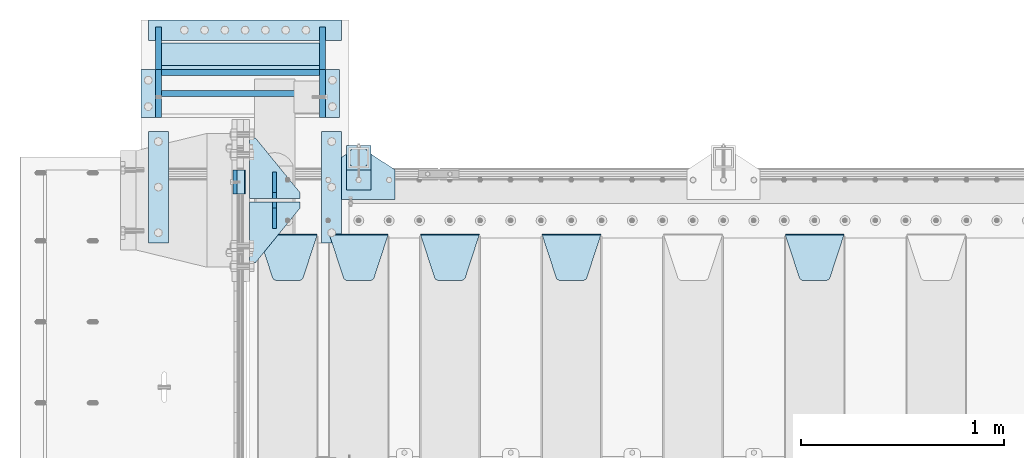
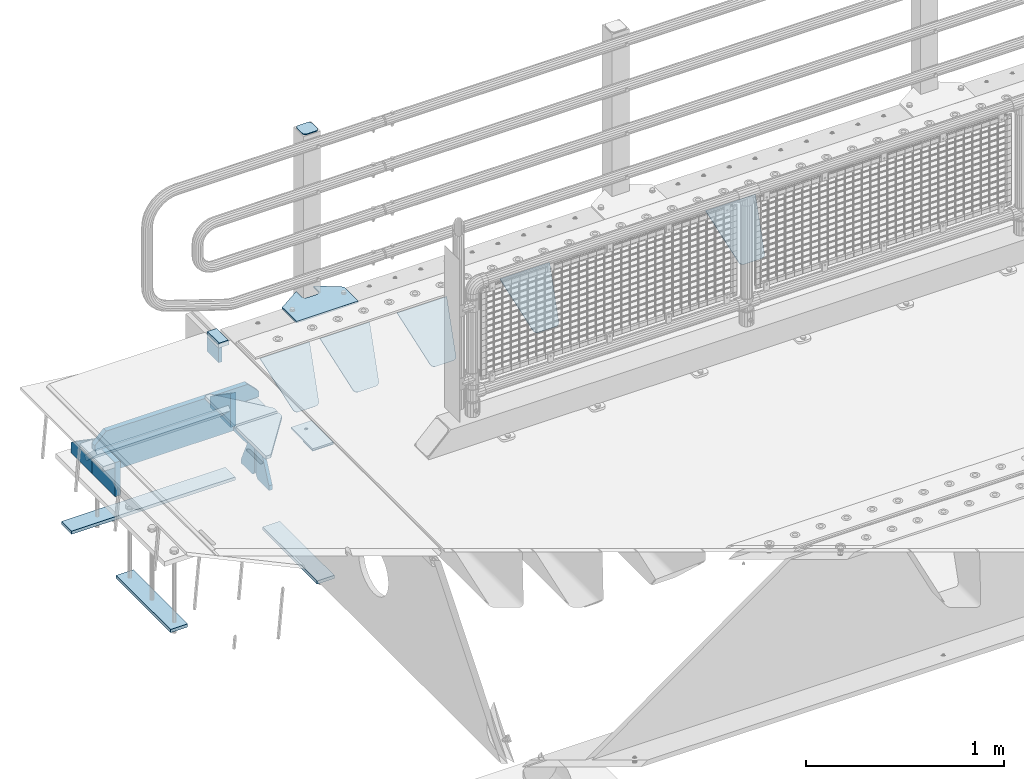
# One storey, part 222 of 257: 27 plates.
"""IFC2X3 building model written with IfcOpenShell, lengths in millimetres."""

from ifc_helpers import new_model, si_unit, frame, origin_with_axes, place, context, subcontext, project, spatial, faceted_brep, material, type_object, element, save


model = new_model("IFC2X3")

# Units and contexts
model_context = context("Model", 3, precision=1e-05, world=origin_with_axes())
body_context = subcontext(model_context, "Body", "Model", "MODEL_VIEW")
ifc_project = project(units=[si_unit("LENGTHUNIT", "METRE", prefix="MILLI"), si_unit("AREAUNIT", "SQUARE_METRE"), si_unit("VOLUMEUNIT", "CUBIC_METRE"), si_unit("MASSUNIT", "GRAM", prefix="KILO"), si_unit("TIMEUNIT", "SECOND"), si_unit("PLANEANGLEUNIT", "RADIAN"), si_unit("SOLIDANGLEUNIT", "STERADIAN"), si_unit("THERMODYNAMICTEMPERATUREUNIT", "DEGREE_CELSIUS"), si_unit("LUMINOUSINTENSITYUNIT", "LUMEN")], contexts=[model_context])

# Site, building, storey
site_placement = place(None, origin_with_axes())
site = spatial("IfcSite", under=ifc_project, at=site_placement, CompositionType="ELEMENT")
building_placement = place(site_placement, origin_with_axes())
building = spatial("IfcBuilding", under=site, at=building_placement, Name="Standard", CompositionType="ELEMENT")
storey_placement = place(building_placement, origin_with_axes())
storey = spatial("IfcBuildingStorey", under=building, at=storey_placement, Name="Undefined", CompositionType="ELEMENT", Elevation=0.0)

# Plates
ifc_material_1 = material()
plate_type_1 = type_object("IfcPlateType", PredefinedType="NOTDEFINED")
plate_1_placement = place(storey_placement, frame((42440.0, 12090.0, -16.0000571410064), z_axis=(-1.0, 0.0, 0.0), x_axis=(0.0, 0.0, 1.0)))
element("IfcPlate", 1, at=plate_1_placement, inside=storey, type_object=plate_type_1, material=ifc_material_1, context=body_context, shape_type="Brep", body=[
    faceted_brep([(0.0, -60.0, 0.0), (2.49929499318569e-09, -59.9999999999991, 60.0), (2.49929144047201e-09, 60.0000000000005, 60.0), (0.0, 60.0, -7.27595761418343e-12), (25.0146748218828, -59.9999999999991, 60.0), (25.0146748218828, 60.0000000000005, 60.0), (26.5597449794466, -59.9999999999991, 59.7552873949098), (26.5597449794466, 60.0000000000005, 59.7552873949098), (27.9535758796897, -59.9999999999991, 59.0451032832789), (27.9535758796897, 60.0000000000009, 59.0451032832789), (29.0597323263517, -59.9999999999991, 57.9389640667287), (29.0597323263517, 60.0000000000005, 57.9389640667287), (29.7699381491534, -59.9999999999991, 56.5451442289705), (29.7699381491534, 60.0000000000009, 56.5451442289705), (30.0146748212763, -59.9999999999991, 55.0000778834001), (30.0146748212762, 60.0000000000009, 55.0000778834001), (30.0154536553013, -59.9999999999991, 5.00007788340736), (30.0154536553013, 60.0000000000005, 5.00007788340736), (29.7707554908505, -59.9999999999991, 3.45497428546514), (29.7707554908505, 60.0000000000009, 3.45497428546514), (29.0605660948355, -59.9999999999995, 2.06111154406972), (29.0605660948355, 60.0000000000009, 2.06111154406972), (27.9544051209123, -59.9999999999995, 0.954933339693525), (27.9544051209123, 60.0000000000009, 0.954933339693525), (26.5605534420796, -59.9999999999991, 0.244722232011554), (26.5605534420796, 60.0000000000009, 0.244722232011554), (25.0154536559091, -59.9999999999991, 7.27595761418343e-12), (25.0154536559091, 60.0000000000009, 7.27595761418343e-12)], [[[0, 1, 2, 3]], [[1, 4, 5, 2]], [[4, 6, 7, 5]], [[6, 8, 9, 7]], [[8, 10, 11, 9]], [[10, 12, 13, 11]], [[12, 14, 15, 13]], [[14, 16, 17, 15]], [[16, 18, 19, 17]], [[18, 20, 21, 19]], [[20, 22, 23, 21]], [[22, 24, 25, 23]], [[24, 26, 27, 25]], [[26, 0, 3, 27]], [[5, 7, 9, 11, 13, 15, 17, 19, 21, 23, 25, 27, 3, 2]], [[26, 24, 22, 20, 18, 16, 14, 12, 10, 8, 6, 4, 1, 0]]]),
])
ifc_material_2 = material(Name="STEEL/S355N")
plate_type_2 = type_object("IfcPlateType", PredefinedType="NOTDEFINED")
plate_2_placement = place(storey_placement, frame((42390.0, 12150.0000855345, -105.984391681158), z_axis=(0.0, -1.0, 0.0), x_axis=(0.0, 0.0, 1.0)))
element("IfcPlate", 2, at=plate_2_placement, inside=storey, type_object=plate_type_2, material=ifc_material_2, context=body_context, shape_type="Brep", body=[
    faceted_brep([(0.0, -10.0, 0.0), (5.7072624315424e-07, -10.0, 120.0), (5.7072624315424e-07, 10.0, 120.0), (0.0, 10.0, 0.0), (89.9845046997072, -10.0, 119.999999999999), (89.9845046997072, 10.0, 119.999999999999), (89.9843902587891, -10.0, 6.45741238258779e-11), (89.9843902587891, 10.0, 6.45741238258779e-11)], [[[0, 1, 2, 3]], [[1, 4, 5, 2]], [[4, 6, 7, 5]], [[6, 0, 3, 7]], [[5, 7, 3, 2]], [[6, 4, 1, 0]]]),
])
plate_type_3 = type_object("IfcPlateType", PredefinedType="NOTDEFINED")
plate_3_placement = place(storey_placement, frame((45105.0, 11831.7677669559, -1.767766952965), z_axis=(0.0, -0.707106781186548, -0.707106781186547), x_axis=(1.0, 0.0, 0.0)))
element("IfcPlate", 3, at=plate_3_placement, inside=storey, type_object=plate_type_3, material=ifc_material_2, context=body_context, shape_type="Brep", body=[
    faceted_brep([(0.0, -2.5, 0.0), (69.345504679477, -2.50000000000091, 300.17173142483), (69.345504679477, 2.5, 300.171731424831), (0.0, 2.5, 0.0), (70.927406119954, -2.50000000000091, 304.8974424154), (70.927406119954, 2.5, 304.8974424154), (73.3818627772271, -2.50000000000091, 309.234538108527), (73.3818627772271, 2.49999999999909, 309.234538108527), (76.6187032999587, -2.5, 313.023683126103), (76.6187032999587, 2.5, 313.023683126103), (80.5190132705029, -2.5, 316.125672595372), (80.5190132705029, 2.5, 316.125672595371), (84.9395038596849, -2.5, 318.426546230476), (84.9395038596849, 2.5, 318.426546230477), (89.7177759439219, -2.5, 319.841774983275), (89.7177759439219, 2.5, 319.841774983275), (94.6782862926484, -2.5, 320.319366455079), (94.6782862926484, 2.5, 320.319366455079), (195.321713707352, -2.5, 320.319366455079), (195.321713707352, 2.5, 320.319366455079), (200.282224056078, -2.5, 319.841774983275), (200.282224056078, 2.49999999999909, 319.841774983275), (205.060496140315, -2.5, 318.426546230476), (205.060496140315, 2.49999999999909, 318.426546230475), (209.480986729497, -2.5, 316.125672595371), (209.480986729497, 2.5, 316.125672595371), (213.381296700041, -2.50000000000091, 313.023683126102), (213.381296700041, 2.5, 313.023683126103), (216.618137222766, -2.50000000000091, 309.234538108527), (216.618137222766, 2.5, 309.234538108527), (219.072593880039, -2.5, 304.897442415399), (219.072593880039, 2.5, 304.897442415399), (220.654495320523, -2.50000000000091, 300.17173142483), (220.654495320523, 2.5, 300.171731424831), (290.0, -2.50000000000091, 0.0), (290.0, 2.5, 9.09494701772928e-13)], [[[0, 1, 2, 3]], [[1, 4, 5, 2]], [[4, 6, 7, 5]], [[6, 8, 9, 7]], [[8, 10, 11, 9]], [[10, 12, 13, 11]], [[12, 14, 15, 13]], [[14, 16, 17, 15]], [[16, 18, 19, 17]], [[18, 20, 21, 19]], [[20, 22, 23, 21]], [[22, 24, 25, 23]], [[24, 26, 27, 25]], [[26, 28, 29, 27]], [[28, 30, 31, 29]], [[30, 32, 33, 31]], [[32, 34, 35, 33]], [[34, 0, 3, 35]], [[5, 7, 9, 11, 13, 15, 17, 19, 21, 23, 25, 27, 29, 31, 33, 35, 3, 2]], [[34, 32, 30, 28, 26, 24, 22, 20, 18, 16, 14, 12, 10, 8, 6, 4, 1, 0]]]),
])
plate_4_placement = place(storey_placement, frame((43905.0, 11831.7677669559, -1.767766952965), z_axis=(0.0, -0.707106781186548, -0.707106781186547), x_axis=(1.0, 0.0, 0.0)))
element("IfcPlate", 4, at=plate_4_placement, inside=storey, type_object=plate_type_3, material=ifc_material_2, context=body_context, shape_type="Brep", body=[
    faceted_brep([(0.0, -2.5, 0.0), (69.345504679477, -2.50000000000091, 300.17173142483), (69.345504679477, 2.5, 300.171731424831), (0.0, 2.5, 0.0), (70.927406119954, -2.50000000000091, 304.8974424154), (70.927406119954, 2.5, 304.8974424154), (73.3818627772271, -2.50000000000091, 309.234538108527), (73.3818627772271, 2.49999999999909, 309.234538108527), (76.6187032999587, -2.5, 313.023683126103), (76.6187032999587, 2.5, 313.023683126103), (80.5190132705029, -2.5, 316.125672595372), (80.5190132705029, 2.5, 316.125672595371), (84.9395038596849, -2.5, 318.426546230476), (84.9395038596849, 2.5, 318.426546230477), (89.7177759439219, -2.5, 319.841774983275), (89.7177759439219, 2.5, 319.841774983275), (94.6782862926484, -2.5, 320.319366455079), (94.6782862926484, 2.5, 320.319366455079), (195.321713707352, -2.5, 320.319366455079), (195.321713707352, 2.5, 320.319366455079), (200.282224056078, -2.5, 319.841774983275), (200.282224056078, 2.49999999999909, 319.841774983275), (205.060496140315, -2.5, 318.426546230476), (205.060496140315, 2.49999999999909, 318.426546230475), (209.480986729497, -2.5, 316.125672595371), (209.480986729497, 2.5, 316.125672595371), (213.381296700041, -2.50000000000091, 313.023683126102), (213.381296700041, 2.5, 313.023683126103), (216.618137222766, -2.50000000000091, 309.234538108527), (216.618137222766, 2.5, 309.234538108527), (219.072593880039, -2.5, 304.897442415399), (219.072593880039, 2.5, 304.897442415399), (220.654495320523, -2.50000000000091, 300.17173142483), (220.654495320523, 2.5, 300.171731424831), (290.0, -2.50000000000091, 0.0), (290.0, 2.5, 9.09494701772928e-13)], [[[0, 1, 2, 3]], [[1, 4, 5, 2]], [[4, 6, 7, 5]], [[6, 8, 9, 7]], [[8, 10, 11, 9]], [[10, 12, 13, 11]], [[12, 14, 15, 13]], [[14, 16, 17, 15]], [[16, 18, 19, 17]], [[18, 20, 21, 19]], [[20, 22, 23, 21]], [[22, 24, 25, 23]], [[24, 26, 27, 25]], [[26, 28, 29, 27]], [[28, 30, 31, 29]], [[30, 32, 33, 31]], [[32, 34, 35, 33]], [[34, 0, 3, 35]], [[5, 7, 9, 11, 13, 15, 17, 19, 21, 23, 25, 27, 29, 31, 33, 35, 3, 2]], [[34, 32, 30, 28, 26, 24, 22, 20, 18, 16, 14, 12, 10, 8, 6, 4, 1, 0]]]),
])
plate_5_placement = place(storey_placement, frame((43305.0, 11831.7677669559, -1.767766952965), z_axis=(0.0, -0.707106781186548, -0.707106781186547), x_axis=(1.0, 0.0, 0.0)))
element("IfcPlate", 5, at=plate_5_placement, inside=storey, type_object=plate_type_3, material=ifc_material_2, context=body_context, shape_type="Brep", body=[
    faceted_brep([(0.0, -2.5, 0.0), (69.345504679477, -2.50000000000091, 300.17173142483), (69.345504679477, 2.5, 300.171731424831), (0.0, 2.5, 0.0), (70.927406119954, -2.50000000000091, 304.8974424154), (70.927406119954, 2.5, 304.8974424154), (73.3818627772271, -2.50000000000091, 309.234538108527), (73.3818627772271, 2.49999999999909, 309.234538108527), (76.6187032999587, -2.5, 313.023683126103), (76.6187032999587, 2.5, 313.023683126103), (80.5190132705029, -2.5, 316.125672595372), (80.5190132705029, 2.5, 316.125672595371), (84.9395038596849, -2.5, 318.426546230476), (84.9395038596849, 2.5, 318.426546230477), (89.7177759439219, -2.5, 319.841774983275), (89.7177759439219, 2.5, 319.841774983275), (94.6782862926484, -2.5, 320.319366455079), (94.6782862926484, 2.5, 320.319366455079), (195.321713707352, -2.5, 320.319366455079), (195.321713707352, 2.5, 320.319366455079), (200.282224056078, -2.5, 319.841774983275), (200.282224056078, 2.49999999999909, 319.841774983275), (205.060496140315, -2.5, 318.426546230476), (205.060496140315, 2.49999999999909, 318.426546230475), (209.480986729497, -2.5, 316.125672595371), (209.480986729497, 2.5, 316.125672595371), (213.381296700041, -2.50000000000091, 313.023683126102), (213.381296700041, 2.5, 313.023683126103), (216.618137222766, -2.50000000000091, 309.234538108527), (216.618137222766, 2.5, 309.234538108527), (219.072593880039, -2.5, 304.897442415399), (219.072593880039, 2.5, 304.897442415399), (220.654495320523, -2.50000000000091, 300.17173142483), (220.654495320523, 2.5, 300.171731424831), (290.0, -2.50000000000091, 0.0), (290.0, 2.5, 9.09494701772928e-13)], [[[0, 1, 2, 3]], [[1, 4, 5, 2]], [[4, 6, 7, 5]], [[6, 8, 9, 7]], [[8, 10, 11, 9]], [[10, 12, 13, 11]], [[12, 14, 15, 13]], [[14, 16, 17, 15]], [[16, 18, 19, 17]], [[18, 20, 21, 19]], [[20, 22, 23, 21]], [[22, 24, 25, 23]], [[24, 26, 27, 25]], [[26, 28, 29, 27]], [[28, 30, 31, 29]], [[30, 32, 33, 31]], [[32, 34, 35, 33]], [[34, 0, 3, 35]], [[5, 7, 9, 11, 13, 15, 17, 19, 21, 23, 25, 27, 29, 31, 33, 35, 3, 2]], [[34, 32, 30, 28, 26, 24, 22, 20, 18, 16, 14, 12, 10, 8, 6, 4, 1, 0]]]),
])
plate_6_placement = place(storey_placement, frame((42855.0, 11831.7677669559, -1.767766952965), z_axis=(0.0, -0.707106781186548, -0.707106781186547), x_axis=(1.0, 0.0, 0.0)))
element("IfcPlate", 6, at=plate_6_placement, inside=storey, type_object=plate_type_3, material=ifc_material_2, context=body_context, shape_type="Brep", body=[
    faceted_brep([(0.0, -2.5, 0.0), (69.345504679477, -2.50000000000091, 300.17173142483), (69.345504679477, 2.5, 300.171731424831), (0.0, 2.5, 0.0), (70.927406119954, -2.50000000000091, 304.8974424154), (70.927406119954, 2.5, 304.8974424154), (73.3818627772271, -2.50000000000091, 309.234538108527), (73.3818627772271, 2.49999999999909, 309.234538108527), (76.6187032999587, -2.5, 313.023683126103), (76.6187032999587, 2.5, 313.023683126103), (80.5190132705029, -2.5, 316.125672595372), (80.5190132705029, 2.5, 316.125672595371), (84.9395038596849, -2.5, 318.426546230476), (84.9395038596849, 2.5, 318.426546230477), (89.7177759439219, -2.5, 319.841774983275), (89.7177759439219, 2.5, 319.841774983275), (94.6782862926484, -2.5, 320.319366455079), (94.6782862926484, 2.5, 320.319366455079), (195.321713707352, -2.5, 320.319366455079), (195.321713707352, 2.5, 320.319366455079), (200.282224056078, -2.5, 319.841774983275), (200.282224056078, 2.49999999999909, 319.841774983275), (205.060496140315, -2.5, 318.426546230476), (205.060496140315, 2.49999999999909, 318.426546230475), (209.480986729497, -2.5, 316.125672595371), (209.480986729497, 2.5, 316.125672595371), (213.381296700041, -2.50000000000091, 313.023683126102), (213.381296700041, 2.5, 313.023683126103), (216.618137222766, -2.50000000000091, 309.234538108527), (216.618137222766, 2.5, 309.234538108527), (219.072593880039, -2.5, 304.897442415399), (219.072593880039, 2.5, 304.897442415399), (220.654495320523, -2.50000000000091, 300.17173142483), (220.654495320523, 2.5, 300.171731424831), (290.0, -2.50000000000091, 0.0), (290.0, 2.5, 9.09494701772928e-13)], [[[0, 1, 2, 3]], [[1, 4, 5, 2]], [[4, 6, 7, 5]], [[6, 8, 9, 7]], [[8, 10, 11, 9]], [[10, 12, 13, 11]], [[12, 14, 15, 13]], [[14, 16, 17, 15]], [[16, 18, 19, 17]], [[18, 20, 21, 19]], [[20, 22, 23, 21]], [[22, 24, 25, 23]], [[24, 26, 27, 25]], [[26, 28, 29, 27]], [[28, 30, 31, 29]], [[30, 32, 33, 31]], [[32, 34, 35, 33]], [[34, 0, 3, 35]], [[5, 7, 9, 11, 13, 15, 17, 19, 21, 23, 25, 27, 29, 31, 33, 35, 3, 2]], [[34, 32, 30, 28, 26, 24, 22, 20, 18, 16, 14, 12, 10, 8, 6, 4, 1, 0]]]),
])
plate_7_placement = place(storey_placement, frame((42505.0, 11831.7677669559, -1.767766952965), z_axis=(0.0, -0.707106781186548, -0.707106781186547), x_axis=(1.0, 0.0, 0.0)))
element("IfcPlate", 7, at=plate_7_placement, inside=storey, type_object=plate_type_3, material=ifc_material_2, context=body_context, shape_type="Brep", body=[
    faceted_brep([(0.0, -2.5, 0.0), (69.345504679477, -2.50000000000091, 300.17173142483), (69.345504679477, 2.5, 300.171731424831), (0.0, 2.5, 0.0), (70.927406119954, -2.50000000000091, 304.8974424154), (70.927406119954, 2.5, 304.8974424154), (73.3818627772271, -2.50000000000091, 309.234538108527), (73.3818627772271, 2.49999999999909, 309.234538108527), (76.6187032999587, -2.5, 313.023683126103), (76.6187032999587, 2.5, 313.023683126103), (80.5190132705029, -2.5, 316.125672595372), (80.5190132705029, 2.5, 316.125672595371), (84.9395038596849, -2.5, 318.426546230476), (84.9395038596849, 2.5, 318.426546230477), (89.7177759439219, -2.5, 319.841774983275), (89.7177759439219, 2.5, 319.841774983275), (94.6782862926484, -2.5, 320.319366455079), (94.6782862926484, 2.5, 320.319366455079), (195.321713707352, -2.5, 320.319366455079), (195.321713707352, 2.5, 320.319366455079), (200.282224056078, -2.5, 319.841774983275), (200.282224056078, 2.49999999999909, 319.841774983275), (205.060496140315, -2.5, 318.426546230476), (205.060496140315, 2.49999999999909, 318.426546230475), (209.480986729497, -2.5, 316.125672595371), (209.480986729497, 2.5, 316.125672595371), (213.381296700041, -2.50000000000091, 313.023683126102), (213.381296700041, 2.5, 313.023683126103), (216.618137222766, -2.50000000000091, 309.234538108527), (216.618137222766, 2.5, 309.234538108527), (219.072593880039, -2.5, 304.897442415399), (219.072593880039, 2.5, 304.897442415399), (220.654495320523, -2.50000000000091, 300.17173142483), (220.654495320523, 2.5, 300.171731424831), (290.0, -2.50000000000091, 0.0), (290.0, 2.5, 9.09494701772928e-13)], [[[0, 1, 2, 3]], [[1, 4, 5, 2]], [[4, 6, 7, 5]], [[6, 8, 9, 7]], [[8, 10, 11, 9]], [[10, 12, 13, 11]], [[12, 14, 15, 13]], [[14, 16, 17, 15]], [[16, 18, 19, 17]], [[18, 20, 21, 19]], [[20, 22, 23, 21]], [[22, 24, 25, 23]], [[24, 26, 27, 25]], [[26, 28, 29, 27]], [[28, 30, 31, 29]], [[30, 32, 33, 31]], [[32, 34, 35, 33]], [[34, 0, 3, 35]], [[5, 7, 9, 11, 13, 15, 17, 19, 21, 23, 25, 27, 29, 31, 33, 35, 3, 2]], [[34, 32, 30, 28, 26, 24, 22, 20, 18, 16, 14, 12, 10, 8, 6, 4, 1, 0]]]),
])
plate_type_4 = type_object("IfcPlateType", PredefinedType="NOTDEFINED")
for number, where, z_axis, x_axis in (
    (8, (42710.0, 12008.0, -515.0), (0.0, 1.0, 0.0), (-1.0, 0.0, 0.0)),
    (9, (42710.0, 11992.0, -515.0), (0.0, -1.0, 0.0), (-1.0, 0.0, 0.0)),
):
    element("IfcPlate", number, at=place(storey_placement, frame(where, z_axis=z_axis, x_axis=x_axis)), inside=storey, type_object=plate_type_4, material=ifc_material_2, context=body_context, shape_type="Brep", body=[
        faceted_brep([(0.0, -10.0, 0.0), (0.0, -10.0, 30.0), (0.0, 10.0, 30.0), (0.0, 10.0, 0.0), (220.0, -10.0, 300.0), (220.0, 10.0, 300.0), (250.0, -10.0, 300.0), (250.0, 10.0, 300.0), (250.0, -10.0, 0.0), (250.0, 10.0, 0.0)], [[[0, 1, 2, 3]], [[1, 4, 5, 2]], [[4, 6, 7, 5]], [[6, 8, 9, 7]], [[8, 0, 3, 9]], [[5, 7, 9, 3, 2]], [[8, 6, 4, 1, 0]]]),
    ])
plate_type_5 = type_object("IfcPlateType", PredefinedType="NOTDEFINED")
for number, where, z_axis, x_axis in (
    (10, (42585.0, 12140.0, -860.0), (0.0, 0.0, 1.0), (0.0, -1.0, 0.0)),
    (11, (42585.0, 11860.0, -860.0), (0.0, 0.0, 1.0), (0.0, 1.0, 0.0)),
):
    element("IfcPlate", number, at=place(storey_placement, frame(where, z_axis=z_axis, x_axis=x_axis)), inside=storey, type_object=plate_type_5, material=ifc_material_2, context=body_context, shape_type="Brep", body=[
        faceted_brep([(0.0, -10.0, 0.0), (0.0, -10.0, 30.0), (0.0, 10.0, 30.0), (0.0, 10.0, 0.0), (102.0, -10.0, 250.0), (102.0, 10.0, 250.0), (132.0, -10.0, 250.0), (132.0, 10.0, 250.0), (132.0, -10.0, 30.0), (132.0, 10.0, 30.0), (131.544232590366, -10.0, 24.790554669992), (131.544232590366, 10.0, 24.790554669992), (130.190778623577, -10.0, 19.7393957002299), (130.190778623577, 10.0, 19.7393957002299), (127.980762113533, -10.0, 15.0), (127.980762113533, 10.0, 15.0), (124.981333293569, -10.0, 10.7163717094038), (124.981333293569, 10.0, 10.7163717094038), (121.283628290596, -10.0, 7.01866670643062), (121.283628290596, 10.0, 7.01866670643062), (117.0, -10.0, 4.01923788646684), (117.0, 10.0, 4.01923788646684), (112.26060429977, -10.0, 1.80922137642278), (112.26060429977, 10.0, 1.80922137642278), (107.209445330008, -10.0, 0.455767409633722), (107.209445330008, 10.0, 0.455767409633722), (102.0, -10.0, 0.0), (102.0, 10.0, 0.0)], [[[0, 1, 2, 3]], [[1, 4, 5, 2]], [[4, 6, 7, 5]], [[6, 8, 9, 7]], [[8, 10, 11, 9]], [[10, 12, 13, 11]], [[12, 14, 15, 13]], [[14, 16, 17, 15]], [[16, 18, 19, 17]], [[18, 20, 21, 19]], [[20, 22, 23, 21]], [[22, 24, 25, 23]], [[24, 26, 27, 25]], [[26, 0, 3, 27]], [[5, 7, 9, 11, 13, 15, 17, 19, 21, 23, 25, 27, 3, 2]], [[26, 24, 22, 20, 18, 16, 14, 12, 10, 8, 6, 4, 1, 0]]]),
    ])
ifc_material_3 = material(Name="STEEL/S355J2")
plate_type_6 = type_object("IfcPlateType", PredefinedType="NOTDEFINED")
plate_8_placement = place(storey_placement, frame((42820.0, 12005.0, 5.00000000004911), z_axis=(0.0, 1.0, 0.0), x_axis=(1.0, 0.0, 0.0)))
element("IfcPlate", 12, at=plate_8_placement, inside=storey, type_object=plate_type_6, material=ifc_material_3, context=body_context, shape_type="Brep", body=[
    faceted_brep([(0.0, -5.0, 0.0), (2.31396552408114e-06, -5.0, 145.0), (2.31396552408114e-06, 5.0, 145.0), (0.0, 5.0, 0.0), (130.0, -5.0, 230.0), (130.0, 5.0, 230.0), (130.0, -5.0, 180.0), (130.0, 5.0, 180.0), (130.48036798992, -5.0, 175.122741949597), (130.48036798992, 5.0, 175.122741949597), (131.903011687216, -5.0, 170.432914190873), (131.903011687216, 5.0, 170.432914190873), (134.213259692435, -5.0, 166.11074417451), (134.213259692435, 5.0, 166.11074417451), (137.322330470335, -5.0, 162.322330470337), (137.322330470335, 5.0, 162.322330470337), (141.110744174512, -5.0, 159.213259692437), (141.110744174512, 5.0, 159.213259692437), (145.432914190875, -5.0, 156.903011687218), (145.432914190875, 5.0, 156.903011687218), (150.122741949599, -5.0, 155.48036798992), (150.122741949599, 5.0, 155.48036798992), (155.0, -5.0, 155.0), (155.0, 5.0, 155.0), (205.0, -5.0, 155.0), (205.0, 5.0, 155.0), (209.877258050401, -5.0, 155.48036798992), (209.877258050401, 5.0, 155.48036798992), (214.567085809125, -5.0, 156.903011687218), (214.567085809125, 5.0, 156.903011687218), (218.889255825488, -5.0, 159.213259692437), (218.889255825488, 5.0, 159.213259692437), (222.677669529665, -5.0, 162.322330470337), (222.677669529665, 5.0, 162.322330470337), (225.786740307565, -5.0, 166.11074417451), (225.786740307565, 5.0, 166.11074417451), (228.096988312784, -5.0, 170.432914190873), (228.096988312784, 5.0, 170.432914190873), (229.51963201008, -5.0, 175.122741949597), (229.51963201008, 5.0, 175.122741949597), (230.0, -5.0, 180.0), (230.0, 5.0, 180.0), (230.0, -5.0, 230.0), (230.0, 5.0, 230.0), (360.0, -5.0, 145.0), (360.0, 5.0, 145.0), (360.0, -5.0, -7.27595761418343e-12), (360.0, 5.0, -7.27595761418343e-12)], [[[0, 1, 2, 3]], [[1, 4, 5, 2]], [[4, 6, 7, 5]], [[6, 8, 9, 7]], [[8, 10, 11, 9]], [[10, 12, 13, 11]], [[12, 14, 15, 13]], [[14, 16, 17, 15]], [[16, 18, 19, 17]], [[18, 20, 21, 19]], [[20, 22, 23, 21]], [[22, 24, 25, 23]], [[24, 26, 27, 25]], [[26, 28, 29, 27]], [[28, 30, 31, 29]], [[30, 32, 33, 31]], [[32, 34, 35, 33]], [[34, 36, 37, 35]], [[36, 38, 39, 37]], [[38, 40, 41, 39]], [[40, 42, 43, 41]], [[42, 44, 45, 43]], [[44, 46, 47, 45]], [[46, 0, 3, 47]], [[5, 7, 9, 11, 13, 15, 17, 19, 21, 23, 25, 27, 29, 31, 33, 35, 37, 39, 41, 43, 45, 47, 3, 2]], [[46, 44, 42, 40, 38, 36, 34, 32, 30, 28, 26, 24, 22, 20, 18, 16, 14, 12, 10, 8, 6, 4, 1, 0]]]),
])
plate_type_7 = type_object("IfcPlateType", PredefinedType="NOTDEFINED")
plate_9_placement = place(storey_placement, frame((42940.0000000001, 12050.0000000002, -850.000000000002), z_axis=(0.0, 1.0, 0.0), x_axis=(1.0, 0.0, 0.0)))
element("IfcPlate", 13, at=plate_9_placement, inside=storey, type_object=plate_type_7, material=ifc_material_3, context=body_context, shape_type="Brep", body=[
    faceted_brep([(66.3639610305399, -5.0, 163.636038969113), (66.3639610305399, 5.0, 163.636038969113), (59.9999999998618, 5.0, 160.999999999791), (59.9999999998618, -5.0, 160.999999999791), (53.6360389691836, 5.0, 163.636038969113), (53.6360389691836, -5.0, 163.636038969113), (50.9999999998618, 5.0, 169.999999999791), (50.9999999998618, -5.0, 169.999999999791), (53.6360389691836, 5.0, 176.363961030469), (53.6360389691836, -5.0, 176.363961030469), (59.9999999998618, 5.0, 178.999999999791), (59.9999999998618, -5.0, 178.999999999791), (66.3639610305399, 5.0, 176.363961030469), (66.3639610305399, -5.0, 176.363961030469), (68.9999999998618, 5.0, 169.999999999791), (68.9999999998618, -5.0, 169.999999999791), (120.0, -5.0, 0.0), (120.0, -5.0, 220.0), (0.0, -5.0, 220.0), (0.0, -5.0, 0.0), (0.0, 5.0, 0.0), (120.0, 5.0, 0.0), (120.0, 5.0, 220.0), (0.0, 5.0, 220.0)], [[[0, 1, 2, 3]], [[3, 2, 4, 5]], [[5, 4, 6, 7]], [[7, 6, 8, 9]], [[9, 8, 10, 11]], [[11, 10, 12, 13]], [[13, 12, 14, 15]], [[15, 14, 1, 0]], [[16, 17, 18, 19], [3, 5, 7, 9, 11, 13, 15, 0]], [[16, 19, 20, 21]], [[17, 16, 21, 22]], [[18, 17, 22, 23]], [[19, 18, 23, 20]], [[22, 21, 20, 23], [10, 8, 6, 4, 2, 1, 14, 12]]]),
])
plate_type_8 = type_object("IfcPlateType", PredefinedType="NOTDEFINED")
plate_10_placement = place(storey_placement, frame((43044.0000000001, 12166.0000000002, 1012.50000000001), z_axis=(0.0, 1.0, 0.0), x_axis=(-1.0, 0.0, 0.0)))
element("IfcPlate", 14, at=plate_10_placement, inside=storey, type_object=plate_type_8, material=ifc_material_3, context=body_context, shape_type="Brep", body=[
    faceted_brep([(0.0, -2.5, 19.0), (0.0, -2.5, 69.0), (0.0, 2.5, 69.0), (0.0, 2.5, 19.0), (0.476369668547704, -2.5, 73.2278977451697), (0.476369668547704, 2.5, 73.2278977451697), (1.88159150985302, -2.5, 77.2437910432327), (1.88159150985302, 2.5, 77.2437910432327), (4.14520183311106, -2.5, 80.8463062353167), (4.14520183311106, 2.5, 80.8463062353167), (7.15369376468152, -2.5, 83.8547981668926), (7.15369376468152, 2.5, 83.8547981668926), (10.7562089567655, -2.5, 86.1184084901452), (10.7562089567655, 2.5, 86.1184084901452), (14.7721022548285, -2.5, 87.5236303314541), (14.7721022548285, 2.5, 87.5236303314541), (19.0, -2.5, 88.0), (19.0, 2.5, 88.0), (69.0, -2.5, 88.0), (69.0, 2.5, 88.0), (73.2278977451715, -2.5, 87.5236303314541), (73.2278977451715, 2.5, 87.5236303314541), (77.2437910432345, -2.5, 86.1184084901452), (77.2437910432345, 2.5, 86.1184084901452), (80.8463062353185, -2.5, 83.8547981668926), (80.8463062353185, 2.5, 83.8547981668926), (83.8547981668889, -2.5, 80.8463062353167), (83.8547981668889, 2.5, 80.8463062353167), (86.118408490147, -2.5, 77.2437910432327), (86.118408490147, 2.5, 77.2437910432327), (87.5236303314523, -2.5, 73.2278977451697), (87.5236303314523, 2.5, 73.2278977451697), (88.0, -2.5, 69.0), (88.0, 2.5, 69.0), (88.0, -2.5, 19.0), (88.0, 2.5, 19.0), (87.5236303314523, -2.5, 14.7721022548303), (87.5236303314523, 2.5, 14.7721022548303), (86.118408490147, -2.5, 10.7562089567673), (86.118408490147, 2.5, 10.7562089567673), (83.8547981668889, -2.5, 7.15369376468334), (83.8547981668889, 2.5, 7.15369376468334), (80.8463062353185, -2.5, 4.14520183310742), (80.8463062353185, 2.5, 4.14520183310742), (77.2437910432345, -2.5, 1.88159150985484), (77.2437910432345, 2.5, 1.88159150985484), (73.2278977451715, -2.5, 0.476369668545885), (73.2278977451715, 2.5, 0.476369668545885), (69.0, -2.5, 0.0), (69.0, 2.5, 0.0), (19.0, -2.5, 0.0), (19.0, 2.5, 0.0), (14.7721022548285, -2.5, 0.476369668545885), (14.7721022548285, 2.5, 0.476369668545885), (10.7562089567655, -2.5, 1.88159150985484), (10.7562089567655, 2.5, 1.88159150985484), (7.15369376468152, -2.5, 4.14520183310742), (7.15369376468152, 2.5, 4.14520183310742), (4.14520183311106, -2.5, 7.15369376468334), (4.14520183311106, 2.5, 7.15369376468334), (1.88159150985302, -2.5, 10.7562089567673), (1.88159150985302, 2.5, 10.7562089567673), (0.476369668547704, -2.5, 14.7721022548303), (0.476369668547704, 2.5, 14.7721022548303)], [[[0, 1, 2, 3]], [[1, 4, 5, 2]], [[4, 6, 7, 5]], [[6, 8, 9, 7]], [[8, 10, 11, 9]], [[10, 12, 13, 11]], [[12, 14, 15, 13]], [[14, 16, 17, 15]], [[16, 18, 19, 17]], [[18, 20, 21, 19]], [[20, 22, 23, 21]], [[22, 24, 25, 23]], [[24, 26, 27, 25]], [[26, 28, 29, 27]], [[28, 30, 31, 29]], [[30, 32, 33, 31]], [[32, 34, 35, 33]], [[34, 36, 37, 35]], [[36, 38, 39, 37]], [[38, 40, 41, 39]], [[40, 42, 43, 41]], [[42, 44, 45, 43]], [[44, 46, 47, 45]], [[46, 48, 49, 47]], [[48, 50, 51, 49]], [[50, 52, 53, 51]], [[52, 54, 55, 53]], [[54, 56, 57, 55]], [[56, 58, 59, 57]], [[58, 60, 61, 59]], [[60, 62, 63, 61]], [[62, 0, 3, 63]], [[5, 7, 9, 11, 13, 15, 17, 19, 21, 23, 25, 27, 29, 31, 33, 35, 37, 39, 41, 43, 45, 47, 49, 51, 53, 55, 57, 59, 61, 63, 3, 2]], [[62, 60, 58, 56, 54, 52, 50, 48, 46, 44, 42, 40, 38, 36, 34, 32, 30, 28, 26, 24, 22, 20, 18, 16, 14, 12, 10, 8, 6, 4, 1, 0]]]),
])
plate_type_9 = type_object("IfcPlateType", PredefinedType="NOTDEFINED")
plate_11_placement = place(storey_placement, frame((42940.0000000001, 12050.0000000002, -857.500000000002), z_axis=(0.0, 1.0, 0.0), x_axis=(1.0, 0.0, 0.0)))
element("IfcPlate", 15, at=plate_11_placement, inside=storey, type_object=plate_type_9, material=ifc_material_3, context=body_context, shape_type="Brep", body=[
    faceted_brep([(0.0, -2.5, 0.0), (0.0, -2.5, 100.0), (0.0, 2.5, 100.0), (0.0, 2.5, 0.0), (120.0, -2.5, 100.0), (120.0, 2.5, 100.0), (120.0, -2.5, 0.0), (120.0, 2.5, 0.0)], [[[0, 1, 2, 3]], [[1, 4, 5, 2]], [[4, 6, 7, 5]], [[6, 0, 3, 7]], [[5, 7, 3, 2]], [[6, 4, 1, 0]]]),
])
plate_type_10 = type_object("IfcPlateType", PredefinedType="NOTDEFINED")
plate_12_placement = place(storey_placement, frame((42805.0, 12765.3571347532, -1017.14966545659), z_axis=(-1.0, 0.0, 0.0), x_axis=(0.0, -0.723355636225729, 0.690475650215467)))
element("IfcPlate", 16, at=plate_12_placement, inside=storey, type_object=plate_type_10, material=ifc_material_2, context=body_context, shape_type="Brep", body=[
    faceted_brep([(0.0, -15.0, 0.0), (3.63797880709171e-12, -15.0, 779.0), (1.81898940354586e-12, 15.0000000000009, 779.0), (0.0, 15.0, 0.0), (152.069061279299, -14.9999999999991, 779.0), (152.069061279301, 14.9999999999991, 779.0), (152.069061279299, -14.9999999999991, 0.0), (152.069061279301, 14.9999999999991, 0.0)], [[[0, 1, 2, 3]], [[1, 4, 5, 2]], [[4, 6, 7, 5]], [[6, 0, 3, 7]], [[5, 7, 3, 2]], [[6, 4, 1, 0]]]),
])
plate_type_11 = type_object("IfcPlateType", PredefinedType="NOTDEFINED")
for number, where, z_axis, x_axis in (
    (17, (41961.0, 12339.9999985338, -1468.0), (0.0, -1.0, 0.0), (1.0, 0.0, 0.0)),
    (18, (42816.0, 12339.9999985338, -1468.0), (0.0, -1.0, 0.0), (1.0, 0.0, 0.0)),
):
    element("IfcPlate", number, at=place(storey_placement, frame(where, z_axis=z_axis, x_axis=x_axis)), inside=storey, type_object=plate_type_11, material=ifc_material_2, context=body_context, shape_type="Brep", body=[
        faceted_brep([(0.0, -10.0, 0.0), (1.00942997960374e-06, -10.0, 550.0), (1.00942997960374e-06, 10.0, 550.0), (0.0, 10.0, 0.0), (100.0, -10.0, 550.0), (100.0, 10.0, 550.0), (100.0, -10.0, 0.0), (100.0, 10.0, 0.0)], [[[0, 1, 2, 3]], [[1, 4, 5, 2]], [[4, 6, 7, 5]], [[6, 0, 3, 7]], [[5, 7, 3, 2]], [[6, 4, 1, 0]]]),
    ])
plate_13_placement = place(storey_placement, frame((41961.0, 12889.9999985338, -1468.0), z_axis=(0.0, -1.0, 0.0), x_axis=(1.0, 0.0, 0.0)))
element("IfcPlate", 19, at=plate_13_placement, inside=storey, type_object=plate_type_11, material=ifc_material_2, context=body_context, shape_type="Brep", body=[
    faceted_brep([(0.0, -10.0, 0.0), (0.0, -10.0, 100.0), (0.0, 10.0, 100.0), (0.0, 10.0, 0.0), (955.0, -10.0, 100.0), (955.0, 10.0, 100.0), (955.0, -10.0, 0.0), (955.0, 10.0, 0.0)], [[[0, 1, 2, 3]], [[1, 4, 5, 2]], [[4, 6, 7, 5]], [[6, 0, 3, 7]], [[5, 7, 3, 2]], [[6, 4, 1, 0]]]),
])
plate_type_12 = type_object("IfcPlateType", PredefinedType="NOTDEFINED")
for number, where, z_axis, x_axis in (
    (20, (42820.0, 12855.0, -1028.0), (0.0, 0.0, 1.0), (0.0, -1.0, 0.0)),
    (21, (42011.0, 12855.0, -1028.0), (0.0, 0.0, 1.0), (0.0, -1.0, 0.0)),
):
    element("IfcPlate", number, at=place(storey_placement, frame(where, z_axis=z_axis, x_axis=x_axis)), inside=storey, type_object=plate_type_12, material=ifc_material_2, context=body_context, shape_type="Brep", body=[
        faceted_brep([(0.0, -15.0, 0.0), (0.0, -15.0, 66.0), (0.0, 15.0, 66.0), (0.0, 15.0, 0.0), (210.0, -15.0, 210.0), (210.0, 15.0, 210.0), (210.0, -15.0, 0.0), (210.0, 15.0, 0.0)], [[[0, 1, 2, 3]], [[1, 4, 5, 2]], [[4, 6, 7, 5]], [[6, 0, 3, 7]], [[5, 7, 3, 2]], [[6, 4, 1, 0]]]),
    ])
plate_14_placement = place(storey_placement, frame((42820.0, 12410.0, -818.000000000005), z_axis=(0.0, 0.0, -1.0), x_axis=(0.0, 1.0, 0.0)))
element("IfcPlate", 22, at=plate_14_placement, inside=storey, type_object=plate_type_12, material=ifc_material_2, context=body_context, shape_type="Brep", body=[
    faceted_brep([(0.0, -15.0, 0.0), (0.0, -15.0, 210.0), (0.0, 15.0, 210.0), (0.0, 15.0, 0.0), (235.0, -15.0, 210.0), (235.0, 15.0, 210.0), (235.0, -15.0, 0.0), (235.0, 15.0, 0.0)], [[[0, 1, 2, 3]], [[1, 4, 5, 2]], [[4, 6, 7, 5]], [[6, 0, 3, 7]], [[5, 7, 3, 2]], [[6, 4, 1, 0]]]),
])
plate_15_placement = place(storey_placement, frame((42026.0, 12630.0, -1028.0), z_axis=(1.0, 0.0, 0.0), x_axis=(0.0, 0.0, 1.0)))
element("IfcPlate", 23, at=plate_15_placement, inside=storey, type_object=plate_type_12, material=ifc_material_2, context=body_context, shape_type="Brep", body=[
    faceted_brep([(0.0, -15.0, 0.0), (3.63797880709171e-12, -15.0, 779.0), (1.81898940354586e-12, 15.0000000000009, 779.0), (0.0, 15.0, 0.0), (210.0, -15.0, 779.0), (210.0, 15.0, 779.0), (210.0, -15.0, 0.0), (210.0, 15.0, 0.0)], [[[0, 1, 2, 3]], [[1, 4, 5, 2]], [[4, 6, 7, 5]], [[6, 0, 3, 7]], [[5, 7, 3, 2]], [[6, 4, 1, 0]]]),
])
plate_16_placement = place(storey_placement, frame((42011.0, 12410.0, -818.000000000004), z_axis=(0.0, 0.0, -1.0), x_axis=(0.0, 1.0, 0.0)))
element("IfcPlate", 24, at=plate_16_placement, inside=storey, type_object=plate_type_12, material=ifc_material_2, context=body_context, shape_type="Brep", body=[
    faceted_brep([(0.0, -15.0, 0.0), (0.0, -15.0, 210.0), (0.0, 15.0, 210.0), (0.0, 15.0, 0.0), (235.0, -15.0, 210.0), (235.0, 15.0, 210.0), (235.0, -15.0, 0.0), (235.0, 15.0, 0.0)], [[[0, 1, 2, 3]], [[1, 4, 5, 2]], [[4, 6, 7, 5]], [[6, 0, 3, 7]], [[5, 7, 3, 2]], [[6, 4, 1, 0]]]),
])
plate_type_13 = type_object("IfcPlateType", PredefinedType="NOTDEFINED")
plate_17_placement = place(storey_placement, frame((41936.0, 12527.5, -788.000000000004), z_axis=(0.0, 0.0, 1.0), x_axis=(1.0, 0.0, 0.0)))
element("IfcPlate", 25, at=plate_17_placement, inside=storey, type_object=plate_type_13, material=ifc_material_2, context=body_context, shape_type="Brep", body=[
    faceted_brep([(0.0, -15.0, 0.0), (0.0, -15.0, 33.0), (0.0, 15.0, 33.0), (0.0, 15.0, 0.0), (67.0, -15.0, 100.0), (67.0, 15.0, 100.0), (892.0, -15.0, 100.0), (892.0, 15.0, 100.0), (959.0, -15.0, 33.0), (959.0, 15.0, 33.0), (959.0, -15.0, 0.0), (959.0, 15.0, 0.0)], [[[0, 1, 2, 3]], [[1, 4, 5, 2]], [[4, 6, 7, 5]], [[6, 8, 9, 7]], [[8, 10, 11, 9]], [[10, 0, 3, 11]], [[5, 7, 9, 11, 3, 2]], [[10, 8, 6, 4, 1, 0]]]),
])
plate_type_14 = type_object("IfcPlateType", PredefinedType="NOTDEFINED")
for number, where, z_axis, x_axis in (
    (26, (42835.0, 12645.0, -833.000000000004), (1.0, 0.0, 0.0), (0.0, -1.0, 0.0)),
    (27, (41926.0, 12645.0, -833.000000000004), (1.0, 0.0, 0.0), (0.0, -1.0, 0.0)),
):
    element("IfcPlate", number, at=place(storey_placement, frame(where, z_axis=z_axis, x_axis=x_axis)), inside=storey, type_object=plate_type_14, material=ifc_material_2, context=body_context, shape_type="Brep", body=[
        faceted_brep([(0.0, -15.0, 0.0), (0.0, -15.0, 70.0), (0.0, 15.0, 70.0), (0.0, 15.0, 0.0), (235.0, -15.0, 70.0), (235.0, 15.0, 70.0), (235.0, -15.0, 0.0), (235.0, 15.0, 0.0)], [[[0, 1, 2, 3]], [[1, 4, 5, 2]], [[4, 6, 7, 5]], [[6, 0, 3, 7]], [[5, 7, 3, 2]], [[6, 4, 1, 0]]]),
    ])

save(model, "model.ifc")
